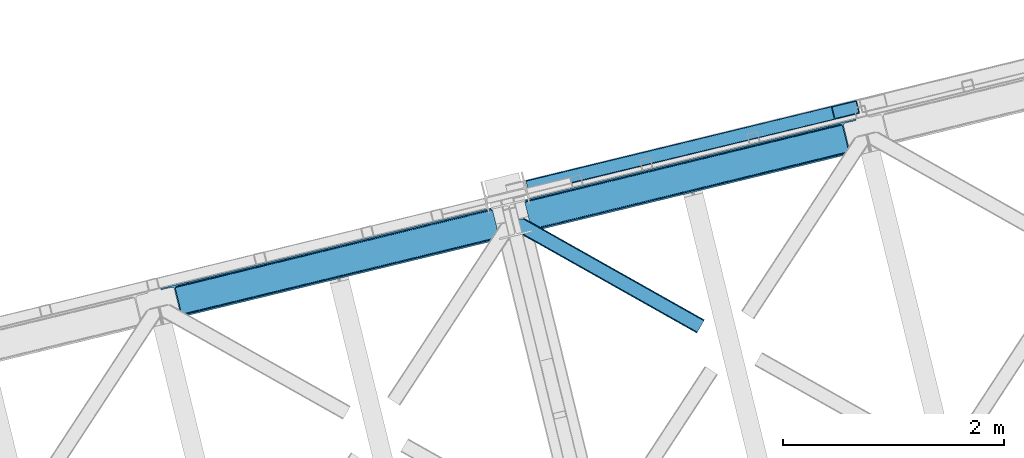
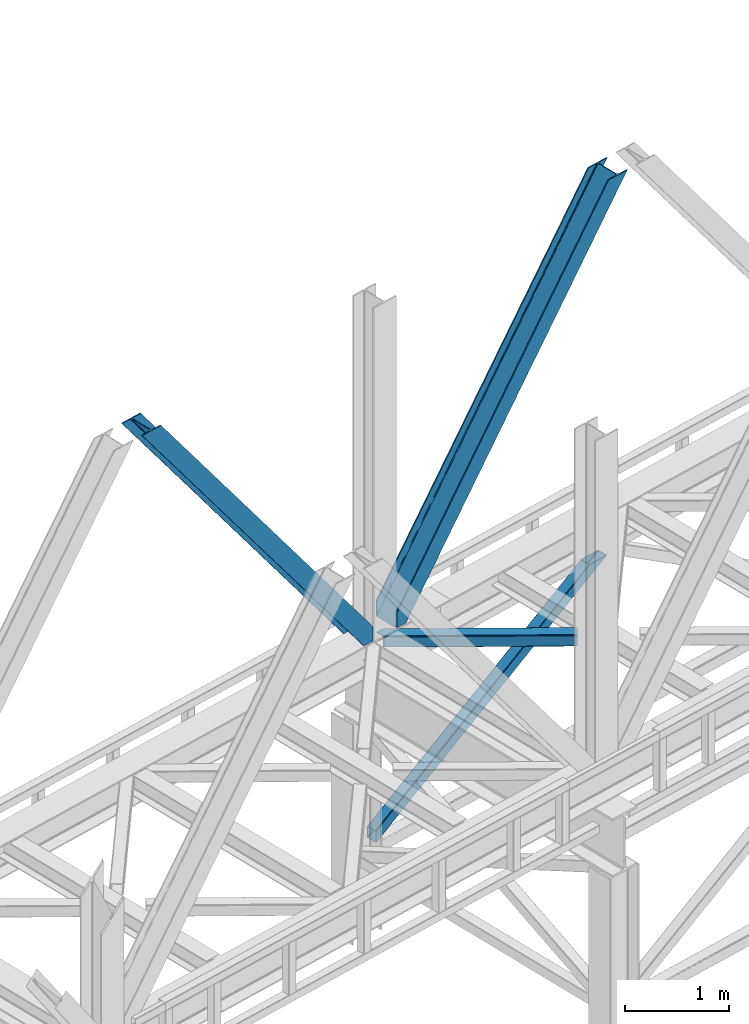
# One storey, part 46 of 92: 4 members.
"""IFC4 building model written with IfcOpenShell, lengths in millimetres."""

from ifc_helpers import new_model, entity, si_unit, converted_unit, derived_unit, direction, frame, origin, place, context, subcontext, project, spatial, triangles, type_object, element, save


model = new_model("IFC4")

# Units and contexts
model_context = context("Model", 3, precision=0.01, world=origin(), true_north=direction((6.12303176911189e-17, 1.0)))
plan_context = context("Plan", 3, precision=0.01, world=origin(), true_north=direction((6.12303176911189e-17, 1.0)))
body_context = subcontext(model_context, "Body", "Model", "MODEL_VIEW")
ifc_project = project(units=[si_unit("LENGTHUNIT", "METRE", prefix="MILLI"), si_unit("AREAUNIT", "SQUARE_METRE"), si_unit("VOLUMEUNIT", "CUBIC_METRE"), converted_unit("PLANEANGLEUNIT", "DEGREE", entity("IfcRatioMeasure", 0.0174532925199433), si_unit("PLANEANGLEUNIT", "RADIAN"), dimensions=[0, 0, 0, 0, 0, 0, 0]), si_unit("MASSUNIT", "GRAM", prefix="KILO"), derived_unit("MASSDENSITYUNIT", [(si_unit("MASSUNIT", "GRAM", prefix="KILO"), 1), (si_unit("LENGTHUNIT", "METRE"), -3)]), derived_unit("MOMENTOFINERTIAUNIT", [(si_unit("LENGTHUNIT", "METRE"), 4)]), si_unit("TIMEUNIT", "SECOND"), si_unit("FREQUENCYUNIT", "HERTZ"), si_unit("THERMODYNAMICTEMPERATUREUNIT", "DEGREE_CELSIUS"), derived_unit("THERMALTRANSMITTANCEUNIT", [(si_unit("MASSUNIT", "GRAM", prefix="KILO"), 1), (si_unit("THERMODYNAMICTEMPERATUREUNIT", "KELVIN"), -1), (si_unit("TIMEUNIT", "SECOND"), -3)]), derived_unit("VOLUMETRICFLOWRATEUNIT", [(si_unit("LENGTHUNIT", "METRE"), 3), (si_unit("TIMEUNIT", "SECOND"), -1)]), derived_unit("MASSFLOWRATEUNIT", [(si_unit("MASSUNIT", "GRAM", prefix="KILO"), 1), (si_unit("TIMEUNIT", "SECOND"), -1)]), derived_unit("ROTATIONALFREQUENCYUNIT", [(si_unit("TIMEUNIT", "SECOND"), -1)]), si_unit("ELECTRICCURRENTUNIT", "AMPERE"), si_unit("ELECTRICVOLTAGEUNIT", "VOLT"), si_unit("POWERUNIT", "WATT"), si_unit("FORCEUNIT", "NEWTON", prefix="KILO"), si_unit("ILLUMINANCEUNIT", "LUX"), si_unit("LUMINOUSFLUXUNIT", "LUMEN"), si_unit("LUMINOUSINTENSITYUNIT", "CANDELA"), derived_unit("USERDEFINED", [(si_unit("MASSUNIT", "GRAM", prefix="KILO"), -1), (si_unit("LENGTHUNIT", "METRE"), -2), (si_unit("TIMEUNIT", "SECOND"), 3), (si_unit("LUMINOUSFLUXUNIT", "LUMEN"), 1)]), derived_unit("LINEARVELOCITYUNIT", [(si_unit("LENGTHUNIT", "METRE"), 1), (si_unit("TIMEUNIT", "SECOND"), -1)]), si_unit("PRESSUREUNIT", "PASCAL"), derived_unit("USERDEFINED", [(si_unit("LENGTHUNIT", "METRE"), -2), (si_unit("MASSUNIT", "GRAM", prefix="KILO"), 1), (si_unit("TIMEUNIT", "SECOND"), -2)]), derived_unit("LINEARFORCEUNIT", [(si_unit("MASSUNIT", "GRAM", prefix="KILO"), 1), (si_unit("LENGTHUNIT", "METRE"), 1), (si_unit("TIMEUNIT", "SECOND"), -2), (si_unit("LENGTHUNIT", "METRE"), -1)]), derived_unit("PLANARFORCEUNIT", [(si_unit("MASSUNIT", "GRAM", prefix="KILO"), 1), (si_unit("LENGTHUNIT", "METRE"), 1), (si_unit("TIMEUNIT", "SECOND"), -2), (si_unit("LENGTHUNIT", "METRE"), -2)])], contexts=[model_context, plan_context])

# Site, building, storey
site_placement = place(None, origin())
site = spatial("IfcSite", under=ifc_project, at=site_placement, CompositionType="ELEMENT")
building_placement = place(site_placement, origin())
building = spatial("IfcBuilding", under=site, at=building_placement, CompositionType="ELEMENT")
storey_placement = place(building_placement, frame((0.0, 0.0, 15900.0)))
storey = spatial("IfcBuildingStorey", under=building, at=storey_placement, Name="05", CompositionType="ELEMENT", Elevation=15900.0)

# Members
member_type_1 = type_object("IfcMemberType", PredefinedType="BRACE")
member_1_placement = place(storey_placement, frame((-46122.29, 9414.76, 3695.0)))
element("IfcMember", 1, at=member_1_placement, inside=storey, type_object=member_type_1, ObjectType="Steel Vertical Brace", PredefinedType="BRACE", context=body_context, shape_type="Tessellation", body=[
    triangles([(3067.37091064453, 755.49225769043, 0.827856445310317), (3068.02668457031, 754.50743408203, 1.13248901367115), (3066.59886474609, 754.045834350585, 0.0), (3064.67805175781, 761.925585937499, 0.0), (3064.21761474609, 752.73196105957, 7.29955444335792), (3064.21761474609, 752.73196105957, 0.0), (3059.99926757813, 741.228012084961, 0.0), (3059.6876586914, 743.591821289063, 30.563250732419), (3059.80393066406, 742.210510253906, 42.2602111816377), (3059.81788330078, 745.527749633789, 0.0), (3059.81788330078, 745.527749633789, 24.1799194335908), (3059.80393066406, 742.210510253906, 171.115136718749), (3059.99926757813, 741.228012084961, 171.175598144531), (3061.29686279297, 749.56936340332, 14.6921264648408), (3061.29686279297, 749.56936340332, 0.0), (3060.72015380859, 747.995040893555, 18.3872497558586), (215.726367187497, 48.9359664916992, 3911.00081176758), (310.450817871089, 72.0264175415032, 3911.00081176758), (192.834741210936, 54.7931671142578, 3911.00081176758), (198.969250488277, 50.2783264160153, 3911.00081176758), (207.010620117188, 48.2214752197269, 3911.00081176758), (189.532617187499, 61.0782485961918, 3911.00081176758), (3062.84095458984, 729.569421386719, 171.175598144531), (313.529699707025, 59.396374511718, 3911.00081176758), (3062.84095458984, 729.569421386719, 0.0), (2945.0109375, 700.846755981445, 0.0), (69.865502929686, 0.0, 3911.00081176758), (2941.93205566406, 713.477380371094, 0.0), (66.78662109375, 12.6300430297852, 3911.00081176758), (161.511071777342, 35.7204940795891, 3911.00081176758), (3036.65650634765, 736.567831420898, 0.0), (3054.3251953125, 759.401321411133, 0.0), (3054.28333740234, 752.301754760741, 0.0), (179.179760742183, 58.5539840698239, 3911.00081176758), (179.13790283203, 51.4544174194325, 3911.00081176758), (3050.91610107422, 745.469613647461, 0.0), (175.7706665039, 44.622857666016, 3911.00081176758), (3044.72578125, 739.944369506835, 0.0), (169.580346679686, 39.0970321655277, 3911.00081176758), (2999.14251708984, 985.772387695311, 0.0), (123.997082519527, 284.925631713866, 3911.00081176758), (2972.94876708984, 997.914669799804, 0.0), (2981.66916503906, 998.62974243164, 0.0), (106.523730468747, 297.782405090331, 3911.00081176758), (97.8033325195283, 297.067913818359, 3911.00081176758), (2989.70588378906, 996.572891235352, 0.0), (114.560449218749, 295.725553894043, 3911.00081176758), (2995.84039306641, 992.058050537109, 0.0), (120.694958496089, 291.211294555664, 3911.00081176758), (3.07888183593604, 273.977462768555, 3911.00081176758), (2878.22431640625, 974.82421875, 0.0), (2875.14543457031, 987.454843139649, 0.0), (0.0, 286.60750579834, 3911.00081176758), (3009.50002441406, 988.296652221679, 0.0), (134.354589843744, 287.449896240234, 3911.00081176758), (143.954003906249, 306.906266784668, 3911.00081176758), (243.668847656249, 346.004461669922, 3911.00081176758), (152.018627929683, 310.283386230469, 3911.00081176758), (137.763684082027, 301.381604003906, 3911.00081176758), (134.391796874996, 294.549462890625, 3911.00081176758), (246.747729492185, 333.373837280273, 3911.00081176758), (2992.97545166015, 1016.17750854492, 171.175598144531), (2992.97545166015, 1016.17750854492, 0.0), (2995.81713867188, 1004.51891784668, 171.175598144531), (2996.10084228515, 1003.55734863281, 171.115136718749), (2996.10084228515, 1003.55734863281, 42.2602111816377), (2995.81713867188, 1004.51891784668, 0.0), (3004.85844726562, 996.247329711914, 0.0), (2997.63563232421, 1000.61683044434, 0.0), (3000.81218261718, 997.712356567383, 0.0), (3007.57921142578, 996.176403808593, 0.0), (2996.63104248047, 1002.27719421387, 30.563250732419), (2997.79841308593, 1000.74124145508, 25.1542785644524), (2999.21228027344, 998.890191650391, 18.6337463378877), (3000.81218261718, 997.712356567383, 14.6921264648408), (3004.85844726562, 996.247329711914, 7.29955444335792), (3009.05819091797, 996.424063110351, 1.13248901367115), (3008.92796630859, 995.248553466796, 0.827856445310317)], [[1, 2, 3], [3, 4, 1], [5, 6, 3], [7, 8, 9], [7, 10, 11], [11, 8, 7], [9, 12, 13], [13, 7, 9], [14, 10, 15], [10, 14, 16], [11, 10, 16], [6, 5, 15], [14, 15, 5], [3, 2, 5], [17, 18, 12], [12, 9, 17], [1, 19, 5], [19, 20, 16], [16, 14, 19], [14, 5, 19], [20, 21, 8], [8, 11, 20], [9, 8, 21], [21, 17, 9], [11, 16, 20], [5, 2, 1], [1, 4, 19], [22, 19, 4], [13, 12, 18], [23, 13, 24], [18, 24, 13], [23, 25, 7], [7, 13, 23], [24, 26, 23], [24, 27, 26], [26, 25, 23], [28, 26, 29], [27, 29, 26], [29, 30, 28], [31, 28, 30], [32, 33, 34], [35, 34, 33], [33, 36, 35], [37, 35, 36], [36, 38, 37], [39, 37, 38], [38, 31, 39], [30, 39, 31], [40, 32, 41], [34, 41, 32], [42, 43, 44], [44, 45, 42], [43, 46, 47], [47, 44, 43], [46, 48, 49], [49, 47, 46], [48, 40, 41], [41, 49, 48], [45, 50, 51], [51, 42, 45], [52, 51, 50], [50, 53, 52], [4, 54, 55], [55, 22, 4], [41, 34, 55], [37, 39, 21], [30, 27, 24], [29, 27, 30], [39, 30, 17], [34, 35, 19], [35, 37, 20], [47, 56, 44], [53, 45, 57], [45, 44, 58], [53, 50, 45], [47, 49, 59], [49, 41, 60], [55, 34, 22], [17, 21, 39], [19, 35, 20], [21, 20, 37], [19, 22, 34], [24, 17, 30], [24, 18, 17], [58, 44, 56], [59, 49, 60], [55, 60, 41], [59, 56, 47], [58, 57, 45], [57, 58, 61], [57, 52, 53], [52, 57, 62], [63, 52, 62], [64, 62, 57], [65, 64, 61], [57, 61, 64], [61, 58, 65], [66, 65, 58], [64, 67, 62], [63, 62, 67], [32, 40, 54], [46, 43, 67], [42, 52, 63], [51, 52, 42], [43, 42, 63], [40, 48, 68], [48, 46, 69], [36, 7, 38], [26, 31, 25], [31, 38, 25], [26, 28, 31], [36, 33, 10], [33, 32, 6], [10, 7, 36], [54, 40, 68], [67, 69, 46], [63, 67, 43], [48, 69, 70], [70, 68, 48], [71, 54, 68], [32, 54, 4], [10, 33, 15], [33, 6, 15], [7, 25, 38], [32, 4, 6], [3, 6, 4], [67, 72, 73], [65, 66, 64], [67, 64, 66], [66, 72, 67], [69, 74, 75], [69, 73, 74], [76, 77, 71], [71, 68, 76], [76, 68, 70], [70, 75, 76], [75, 70, 69], [73, 69, 67], [60, 78, 76], [76, 59, 60], [76, 75, 59], [75, 74, 59], [78, 77, 76], [54, 78, 60], [60, 55, 54], [73, 59, 74], [59, 73, 72], [56, 59, 72], [72, 66, 56], [58, 56, 66], [77, 78, 71], [54, 71, 78]]),
])
member_type_2 = type_object("IfcMemberType", PredefinedType="BRACE")
member_2_placement = place(storey_placement, frame((-42823.61, 10220.12, 3695.0)))
element("IfcMember", 2, at=member_2_placement, inside=storey, type_object=member_type_2, ObjectType="Steel Vertical Brace", PredefinedType="BRACE", context=body_context, shape_type="Tessellation", body=[
    triangles([(58.5313110351563, 27.8808563232415, 0.0), (60.452124023439, 20.0011047363278, 0.0), (59.0987182617173, 20.928955078125, 0.827856445310317), (58.97314453125, 19.7534454345696, 1.13248901367115), (72.2095458984404, 11.6585906982418, 0.0), (71.4002929687485, 13.9003143310547, 30.563250732419), (70.228271484375, 15.4362670898427, 25.1542785644524), (72.2095458984404, 11.6585906982418, 171.175598144531), (71.9304931640654, 12.6201599121086, 42.2602111816377), (71.9304931640654, 12.6201599121086, 171.115136718749), (70.3957031250029, 15.5606781005863, 0.0), (68.8190551757798, 17.2873168945316, 18.6337463378877), (67.2191528320327, 18.4663146972653, 14.6921264648408), (63.168237304686, 19.9301788330067, 7.29955444335792), (63.168237304686, 19.9301788330067, 0.0), (67.2191528320327, 18.4663146972653, 0.0), (2821.28360595703, 682.803671264648, 3911.00081176758), (2916.00805664063, 705.894122314452, 3911.00081176758), (2933.63488769531, 721.628045654297, 3911.00081176758), (2930.26765136719, 714.795904541015, 3911.00081176758), (2933.67674560547, 728.727612304687, 3911.00081176758), (2924.07733154297, 709.270660400391, 3911.00081176758), (2824.36248779297, 670.173046874999, 3911.00081176758), (75.0512329101548, 0.0, 171.175598144531), (75.0512329101548, 0.0, 0.0), (192.881249999999, 28.7226654052738, 0.0), (3068.03133544922, 729.570584106445, 3911.00081176758), (3064.95245361328, 742.200045776366, 3911.00081176758), (189.802368164063, 41.3532897949208, 0.0), (2970.22335205078, 719.109594726562, 3911.00081176758), (95.0779174804702, 18.2628387451168, 0.0), (2961.50760498047, 718.395684814453, 3911.00081176758), (86.3621704101533, 17.5477661132809, 0.0), (2953.47088623047, 720.451373291015, 3911.00081176758), (78.32080078125, 19.6046173095692, 0.0), (2947.33172607422, 724.966213989257, 3911.00081176758), (72.1862915039092, 24.1194580078118, 0.0), (2944.02960205078, 731.251876831055, 3911.00081176758), (68.8841674804717, 30.4039581298821, 0.0), (2888.85157470703, 957.624105834961, 3911.00081176758), (13.7061401367173, 256.776187133788, 0.0), (2888.88878173828, 964.722509765625, 3911.00081176758), (13.7433471679688, 263.875753784179, 0.0), (2892.26066894531, 971.554650878907, 3911.00081176758), (17.115234375, 270.707894897461, 0.0), (2898.45098876953, 977.079895019531, 3911.00081176758), (23.3055541992217, 276.233139038086, 0.0), (2906.52026367188, 980.457595825195, 3911.00081176758), (31.3748291015654, 279.609677124023, 0.0), (3001.24471435547, 1003.548046875, 3911.00081176758), (126.099279785158, 302.700128173828, 0.0), (2998.16583251953, 1016.17750854492, 3911.00081176758), (123.020397949222, 315.330752563475, 0.0), (2878.49406738281, 955.098678588867, 3911.00081176758), (3.3486328125, 254.251922607422, 0.0), (2869.05743408203, 965.899182128906, 3911.00081176758), (2861.02071533203, 967.956033325196, 3911.00081176758), (2754.49698486328, 956.781134033203, 3911.00081176758), (2852.30496826172, 967.242123413085, 3911.00081176758), (2757.57586669922, 944.150509643554, 3911.00081176758), (2875.19194335937, 961.384341430663, 3911.00081176758), (5.19038085937791, 286.608087158203, 171.175598144531), (5.19038085937791, 286.608087158203, 0.0), (8.03206787109229, 274.94949645996, 171.175598144531), (8.22275390625146, 273.966998291015, 171.115136718749), (8.22275390625146, 273.966998291015, 42.2602111816377), (8.03206787109229, 274.94949645996, 0.0), (3.80906982421584, 263.445547485351, 0.0), (6.72982177734229, 266.608145141601, 0.0), (8.21345214844041, 270.649758911133, 0.0), (1.42781982421729, 262.130511474608, 0.0), (3.80906982421584, 263.445547485351, 7.29955444335792), (8.34367675780959, 272.58568725586, 30.563250732419), (8.21345214844041, 270.649758911133, 24.1799194335908), (7.30653076172166, 268.182467651366, 18.3872497558586), (6.72982177734229, 266.608145141601, 14.6921264648408), (0.0, 261.670074462891, 1.13248901367115), (0.65577392578416, 260.685250854493, 0.827856445310317)], [[1, 2, 3], [4, 3, 2], [5, 6, 7], [5, 8, 9], [10, 9, 8], [9, 6, 5], [11, 12, 13], [11, 7, 12], [14, 4, 2], [2, 15, 14], [16, 13, 14], [14, 15, 16], [13, 16, 11], [7, 11, 5], [17, 18, 10], [9, 10, 18], [19, 3, 14], [14, 20, 19], [14, 13, 20], [13, 12, 20], [3, 4, 14], [19, 21, 1], [1, 3, 19], [6, 20, 7], [6, 22, 20], [12, 7, 20], [18, 22, 9], [6, 9, 22], [8, 17, 10], [23, 8, 24], [8, 23, 17], [25, 24, 5], [8, 5, 24], [23, 26, 27], [26, 23, 24], [25, 26, 24], [28, 27, 26], [26, 29, 28], [30, 28, 29], [29, 31, 30], [32, 30, 31], [31, 33, 32], [34, 32, 33], [33, 35, 34], [36, 34, 35], [35, 37, 36], [38, 36, 37], [37, 39, 38], [40, 38, 39], [39, 41, 40], [42, 40, 43], [41, 43, 40], [44, 42, 45], [43, 45, 42], [46, 44, 47], [45, 47, 44], [48, 46, 49], [47, 49, 46], [50, 48, 51], [49, 51, 48], [52, 50, 53], [51, 53, 50], [21, 54, 55], [55, 1, 21], [54, 21, 40], [20, 22, 32], [18, 23, 27], [17, 23, 18], [22, 18, 30], [21, 19, 36], [19, 20, 34], [56, 46, 57], [58, 59, 52], [59, 57, 48], [58, 60, 59], [56, 61, 44], [61, 54, 42], [40, 21, 38], [30, 32, 22], [36, 19, 34], [32, 34, 20], [36, 38, 21], [27, 30, 18], [27, 28, 30], [48, 57, 46], [44, 61, 42], [40, 42, 54], [44, 46, 56], [48, 52, 59], [52, 48, 50], [58, 53, 62], [58, 52, 53], [53, 63, 62], [64, 58, 62], [60, 64, 65], [64, 60, 58], [59, 60, 65], [65, 66, 59], [67, 64, 62], [62, 63, 67], [11, 35, 5], [68, 41, 55], [69, 70, 43], [69, 43, 68], [55, 71, 68], [67, 63, 47], [67, 45, 70], [55, 39, 1], [37, 16, 15], [2, 1, 15], [15, 1, 39], [11, 16, 37], [25, 5, 33], [39, 55, 41], [49, 47, 63], [43, 70, 45], [47, 45, 67], [43, 41, 68], [53, 49, 63], [53, 51, 49], [31, 25, 33], [35, 11, 37], [39, 37, 15], [35, 33, 5], [31, 26, 25], [26, 31, 29], [72, 68, 71], [67, 73, 66], [67, 70, 74], [74, 73, 67], [64, 67, 66], [66, 65, 64], [75, 70, 76], [75, 74, 70], [69, 76, 70], [76, 69, 72], [68, 72, 69], [71, 77, 72], [78, 61, 72], [61, 56, 75], [75, 76, 61], [76, 72, 61], [56, 57, 73], [73, 74, 56], [57, 59, 66], [66, 73, 57], [74, 75, 56], [72, 77, 78], [54, 61, 55], [78, 55, 61], [71, 55, 78], [78, 77, 71]]),
])
member_type_3 = type_object("IfcMemberType", PredefinedType="BRACE")
member_3_placement = place(storey_placement, frame((-42813.64, 10559.94, 965.74)))
element("IfcMember", 3, at=member_3_placement, inside=storey, type_object=member_type_3, ObjectType="Steel Vertical Brace", PredefinedType="BRACE", context=body_context, shape_type="Tessellation", body=[
    triangles([(2998.54720458984, 840.489395141602, 1902.27225952148), (3024.23865966796, 734.56097717285, 1902.27225952148), (42.5415893554673, 11.3690734863267, 4.45903015136719), (16.6268920898438, 117.244006347655, 4.31717834472511), (0.176733398438955, 120.724026489257, 0.782510375975107), (0.0, 121.443749999999, 4.34159545898365), (2981.88310546875, 844.679837036132, 1902.27225952148), (2987.68275146484, 845.460021972656, 1902.27225952148), (2992.88243408203, 844.937960815429, 1902.27225952148), (7.26932373047021, 120.796115112304, 1.96615905761428), (2996.70080566406, 843.192718505859, 1902.27225952148), (13.8177612304644, 119.712460327148, 3.70442504882521), (0.213940429683134, 120.565896606444, 0.0), (3016.85771484375, 725.1650390625, 1902.27225952148), (29.4307617187515, 0.711584472655886, 0.868551635740005), (35.8768798828096, 3.93231811523401, 2.12312622070021), (29.3935546875, 0.86041259765625, 0.127899169921875), (3011.34642333984, 723.202368164062, 1902.27225952148), (29.6028442382813, 0.0, 4.43112487792678), (3021.24349365234, 728.013702392578, 1902.27225952148), (3023.83868408203, 731.313500976561, 1902.27225952148), (41.1881835937456, 7.89021606445203, 3.8532531738274), (0.0, 121.443749999999, 132.509353637695), (2780.51865234375, 795.839794921874, 1902.27225952148), (0.279052734375, 120.305447387695, 135.835894775388), (2775.00270996094, 793.875961303711, 1902.27225952148), (0.55810546875, 119.167144775391, 139.162435913084), (2770.61693115234, 791.028460693358, 1902.27225952148), (1.22783203124709, 116.419638061523, 140.541421508788), (2768.02639160156, 787.728662109374, 1902.27225952148), (1.89755859375146, 113.670968627928, 141.921569824219), (2767.62176513672, 784.481185913086, 1902.27225952148), (2793.31787109375, 678.552767944335, 1902.27225952148), (27.709936523439, 7.77161865234302, 141.999472045896), (28.379663085936, 5.02411193847547, 140.622811889647), (2795.16427001953, 675.849444580077, 1902.27225952148), (29.0493896484331, 2.27544250488245, 139.247314453125), (2798.97799072265, 674.104202270508, 1902.27225952148), (29.3284423828081, 1.13713989257667, 135.92309875488), (2804.18232421875, 673.58214111328, 1902.27225952148), (29.6028442382813, 0.0, 132.597720336911), (2809.98197021485, 674.362326049804, 1902.27225952148), (3.90208740234084, 110.042120361328, 0.32207336425563), (27.914575195311, 11.9376434326168, 0.453460693359375), (27.3099609374985, 9.42151794433448, 0.118597412107192), (2.32078857421584, 111.925726318359, 0.00930175781104481), (3015.90893554688, 736.656198120116, 1902.27225952148), (2992.10108642578, 834.810671997069, 1902.27225952148), (1.6278076171875, 114.77322692871, 3.08236999511428), (2986.44096679687, 839.258074951171, 1902.27225952148), (2981.23663330078, 839.780136108398, 1902.27225952148), (2.17196044921729, 112.538479614257, 0.67088928222438), (2990.2546875, 837.512832641602, 1902.27225952148), (1.09295654296875, 116.966116333007, 5.44850463866896), (2975.43698730469, 839.001113891602, 1902.27225952148), (0.94877929687209, 117.557940673827, 9.04828491210719), (28.379663085936, 5.02411193847547, 5.80429687499782), (28.658715820311, 3.88580932617151, 9.13083801269386), (3003.01669921875, 725.297589111327, 1902.27225952148), (28.100610351561, 6.16241455078125, 2.47775573730178), (3008.52799072266, 727.261422729491, 1902.27225952148), (27.4680908203081, 8.76109313964844, 0.596475219725107), (3012.91376953125, 730.108923339843, 1902.27225952148), (3015.50430908203, 733.408721923828, 1902.27225952148), (0.94877929687209, 117.557940673827, 127.808477783201), (2788.84837646484, 793.744573974609, 1902.27225952148), (2.17196044921729, 112.532666015624, 135.841708374021), (2776.36076660156, 785.633441162108, 1902.27225952148), (2775.95614013672, 782.385964965819, 1902.27225952148), (1.50223388672021, 115.281335449217, 134.461560058593), (2778.95130615234, 788.933239746093, 1902.27225952148), (1.22783203124709, 116.419638061523, 131.135018920897), (2783.33708496093, 791.780740356444, 1902.27225952148), (2.84168701171438, 109.785159301757, 137.220693969724), (2805.42410888672, 679.784088134766, 1902.27225952148), (2801.6103881836, 681.529330444335, 1902.27225952148), (2816.4280883789, 680.041049194335, 1902.27225952148), (2810.62844238281, 679.262026977538, 1902.27225952148), (2799.75933837891, 684.231491088867, 1902.27225952148), (28.379663085936, 5.02411193847547, 131.216409301756), (28.100610351561, 6.16241455078125, 134.541787719725), (27.430883789064, 8.90992126464698, 135.917285156247), (26.7611572265596, 11.6574279785145, 137.292782592773), (28.658715820311, 3.88580932617151, 127.891030883788)], [[1, 2, 3], [3, 4, 1], [5, 6, 7], [8, 9, 10], [10, 5, 8], [11, 1, 4], [4, 12, 11], [9, 11, 12], [12, 10, 9], [10, 13, 5], [7, 8, 5], [14, 15, 16], [15, 17, 16], [15, 14, 18], [18, 19, 15], [16, 20, 14], [21, 20, 22], [16, 22, 20], [2, 21, 3], [22, 3, 21], [6, 23, 24], [24, 7, 6], [23, 25, 26], [25, 27, 28], [27, 29, 30], [29, 31, 32], [32, 30, 29], [30, 28, 27], [28, 26, 25], [26, 24, 23], [33, 32, 34], [31, 34, 32], [35, 36, 33], [37, 38, 36], [39, 40, 38], [41, 42, 40], [40, 39, 41], [38, 37, 39], [36, 35, 37], [33, 34, 35], [41, 19, 42], [18, 42, 19], [43, 10, 12], [44, 3, 22], [44, 22, 16], [3, 44, 4], [12, 4, 43], [43, 4, 44], [16, 45, 44], [16, 17, 45], [10, 46, 13], [46, 10, 43], [47, 48, 44], [43, 44, 48], [49, 50, 51], [52, 53, 50], [53, 46, 43], [53, 52, 46], [43, 48, 53], [50, 49, 52], [51, 54, 49], [51, 55, 54], [56, 54, 55], [57, 58, 59], [60, 57, 61], [62, 60, 63], [64, 47, 44], [44, 45, 64], [45, 62, 64], [63, 64, 62], [61, 63, 60], [59, 61, 57], [65, 56, 66], [55, 66, 56], [67, 68, 69], [70, 71, 68], [72, 73, 71], [65, 66, 73], [73, 72, 65], [71, 70, 72], [68, 67, 70], [69, 74, 67], [53, 9, 8], [48, 47, 1], [11, 53, 1], [53, 11, 9], [53, 48, 1], [50, 53, 8], [55, 7, 24], [7, 50, 8], [51, 7, 55], [51, 50, 7], [20, 64, 14], [47, 2, 1], [2, 64, 21], [64, 2, 47], [20, 21, 64], [18, 59, 42], [14, 64, 63], [63, 61, 18], [61, 59, 18], [18, 14, 63], [71, 26, 68], [24, 66, 55], [24, 73, 66], [71, 24, 26], [71, 73, 24], [69, 32, 33], [68, 26, 28], [30, 68, 28], [68, 30, 32], [69, 68, 32], [40, 75, 76], [42, 59, 77], [77, 78, 42], [78, 75, 42], [40, 42, 75], [38, 40, 76], [33, 79, 69], [76, 33, 36], [33, 76, 79], [36, 38, 76], [41, 39, 80], [81, 35, 82], [37, 81, 39], [81, 37, 35], [80, 39, 81], [83, 31, 74], [82, 35, 34], [34, 83, 82], [34, 31, 83], [80, 84, 41], [19, 60, 17], [19, 41, 84], [84, 58, 19], [19, 58, 57], [60, 19, 57], [60, 62, 17], [23, 65, 72], [70, 25, 72], [31, 29, 67], [31, 67, 74], [67, 29, 70], [25, 23, 72], [70, 29, 27], [70, 27, 25], [23, 56, 65], [49, 13, 46], [49, 54, 5], [5, 13, 49], [54, 56, 6], [23, 6, 56], [54, 6, 5], [69, 79, 83], [83, 74, 69], [84, 80, 78], [80, 81, 75], [81, 82, 76], [82, 83, 79], [79, 76, 82], [76, 75, 81], [75, 78, 80], [78, 77, 84], [58, 84, 77], [77, 59, 58]]),
])
member_type_4 = type_object("IfcMemberType", PredefinedType="BRACE")
member_4_placement = place(storey_placement, frame((-42920.63, 9296.6, 3511.0)))
element("IfcMember", 4, at=member_4_placement, inside=storey, type_object=member_type_4, ObjectType="Steel Horizontal Brace", PredefinedType="BRACE", context=body_context, shape_type="Tessellation", body=[
    triangles([(1656.08961181641, 0.0, 122.500662231447), (1656.74073486328, 1.16039428710974, 129.197927856447), (23.8869140625029, 919.172383117675, 122.500662231447), (23.4543823242202, 920.945530700683, 129.197927856447), (1658.60573730469, 4.46600646972547, 134.874325561526), (22.2265502929731, 925.991734313964, 134.874325561526), (1661.38696289063, 9.41279754638708, 138.667117309571), (20.3848022460952, 933.543598937988, 138.667117309571), (1664.67513427735, 15.2484878540035, 139.999594116212), (18.2128417968779, 942.452357482909, 139.999594116212), (1656.08961181641, 0.0, 17.5000946044929), (23.8869140625029, 919.172383117675, 17.5000946044929), (1716.19757080078, 106.738252258301, 139.999594116212), (69.4422729492217, 1034.10722808838, 139.999594116212), (0.0, 1017.17919158936, 139.999594116212), (1719.48574218751, 112.573361206054, 138.667117309571), (78.9672729492231, 1036.42917938232, 138.667117309571), (1722.27161865235, 117.520733642577, 134.874325561526), (87.0458496093779, 1038.39766387939, 134.874325561526), (1724.13197021485, 120.825764465331, 129.197927856447), (92.4408691406279, 1039.71269989014, 129.197927856447), (1724.78309326172, 121.986158752441, 122.500662231447), (94.3337768554702, 1040.17429962158, 122.500662231447), (1724.78309326172, 121.986158752441, 17.5000946044929), (94.3337768554702, 1040.17429962158, 17.5000946044929), (1656.74073486328, 1.16039428710974, 10.8028289794929), (1658.60573730469, 4.46600646972547, 5.12526855468968), (196.053149414067, 824.821165466308, 8.8831787109375), (196.071752929689, 825.066499328614, 8.50064392089917), (23.3660156250044, 921.307136535645, 10.8691040039084), (195.062512207034, 824.999061584473, 9.50058288574292), (195.732238769531, 824.879301452636, 9.08316650390771), (23.2590454101592, 921.747807312011, 9.50058288574292), (195.220642089844, 828.569773864745, 5.12526855468968), (1664.67513427735, 15.2484878540035, 0.0), (1661.38696289063, 9.41279754638708, 1.33247680664135), (193.378894042973, 836.122801208496, 1.33247680664135), (191.206933593756, 845.031559753417, 0.0), (1716.19757080078, 106.738252258301, 0.0), (157.157849121097, 984.711405944823, 0.0), (191.346459960943, 843.223530578613, 9.20757751465135), (191.290649414063, 844.068827819823, 8.85411071777344), (191.104614257813, 845.46060333252, 8.41343994140698), (18.8686157226621, 939.77345123291, 9.50058288574292), (1724.13197021485, 120.825764465331, 10.8028289794929), (92.0548461914077, 1039.61851959228, 10.8702667236357), (150.916369628911, 1006.08800811767, 9.50058288574292), (1722.27161865235, 117.520733642577, 5.12526855468968), (153.144140625001, 1001.17202911377, 5.12526855468968), (152.293029785156, 1004.67646636963, 8.50064392089917), (151.604699707037, 1005.38223724365, 9.00061340332104), (91.5804565429717, 1039.50341033936, 9.50058288574292), (1719.48574218751, 112.573361206054, 1.33247680664135), (154.985888671879, 993.620164489746, 1.33247680664135), (156.246276855469, 986.7019821167, 9.11688537597729), (155.809094238284, 987.634483337402, 9.42384338378906), (156.692761230472, 985.761341857909, 8.80760192871094), (157.129943847656, 984.828840637207, 8.50064392089917), (155.311450195317, 988.062364196778, 9.50058288574292), (72.3072143554746, 1034.80602264404, 9.50058288574292), (159.427478027348, 975.399183654785, 6.99957275390625), (188.937304687504, 854.343782043457, 6.99957275390625), (1668.11213378907, 21.3475341796875, 6.99957275390625), (1712.76522216797, 100.639205932617, 6.99957275390625), (19.9569213867217, 935.302793884277, 12.1260040283232), (1662.0380859375, 10.5656341552731, 12.1260040283232), (1664.82396240235, 15.5124252319329, 8.3320495605476), (1659.52196044922, 6.09904632568396, 24.4996673583992), (1660.177734375, 7.26002197265552, 17.8035644531265), (21.6172851562515, 928.484605407715, 24.4996673583992), (21.1847534179688, 930.256590270996, 17.8035644531265), (1716.04874267578, 106.47431488037, 8.3320495605476), (1718.83461914063, 111.421105957032, 12.1260040283232), (77.0883178710938, 1035.97106781006, 12.1260040283232), (1720.69497070313, 114.726718139647, 17.8035644531265), (82.4833374023438, 1037.2861038208, 17.8035644531265), (1721.35074462891, 115.887112426757, 24.4996673583992), (84.3808959960952, 1037.74770355225, 24.4996673583992), (1659.52196044922, 6.09904632568396, 115.501089477541), (21.6172851562515, 928.484605407715, 115.501089477541), (21.1847534179688, 930.256590270996, 122.196029663086), (19.9569213867217, 935.302793884277, 127.87475280762), (15.9432128906265, 951.764579772949, 133.000021362306), (18.1151733398438, 942.855821228028, 131.667544555665), (0.0, 1017.17919158936, 133.000021362306), (1668.11213378907, 21.3475341796875, 133.000021362306), (1664.82396240235, 15.5124252319329, 131.667544555665), (1662.0380859375, 10.5656341552731, 127.87475280762), (1660.177734375, 7.26002197265552, 122.196029663086), (1718.83461914063, 111.421105957032, 127.87475280762), (1720.69497070313, 114.726718139647, 122.196029663086), (1721.35074462891, 115.887112426757, 115.501089477541), (1712.76522216797, 100.639205932617, 133.000021362306), (1716.04874267578, 106.47431488037, 131.667544555665), (77.0883178710938, 1035.97106781006, 127.87475280762), (69.0143920898481, 1034.00258331299, 131.667544555665), (82.4833374023438, 1037.2861038208, 122.196029663086), (59.4893920898467, 1031.68063201904, 133.000021362306), (84.3808959960952, 1037.74770355225, 115.501089477541)], [[1, 2, 3], [4, 3, 2], [2, 5, 4], [6, 4, 5], [5, 7, 6], [8, 6, 7], [7, 9, 8], [10, 8, 9], [11, 1, 12], [3, 12, 1], [13, 10, 9], [10, 13, 14], [15, 10, 14], [13, 16, 17], [17, 14, 13], [16, 18, 19], [19, 17, 16], [18, 20, 21], [21, 19, 18], [20, 22, 23], [23, 21, 20], [22, 24, 23], [25, 23, 24], [26, 11, 12], [27, 28, 29], [26, 30, 31], [31, 27, 26], [31, 32, 27], [30, 33, 31], [29, 34, 27], [35, 36, 37], [37, 38, 35], [36, 27, 34], [34, 37, 36], [12, 30, 26], [39, 35, 38], [38, 40, 39], [41, 42, 29], [42, 43, 29], [41, 31, 33], [33, 44, 41], [45, 46, 25], [46, 45, 47], [45, 48, 49], [49, 50, 45], [45, 50, 51], [51, 47, 45], [47, 52, 46], [48, 53, 54], [54, 49, 48], [53, 39, 40], [40, 54, 53], [25, 24, 45], [51, 55, 56], [50, 57, 55], [50, 58, 57], [47, 59, 52], [60, 52, 59], [61, 40, 62], [54, 58, 49], [58, 54, 40], [49, 58, 50], [40, 61, 58], [62, 40, 38], [37, 43, 38], [43, 37, 34], [38, 43, 62], [34, 29, 43], [63, 64, 62], [61, 62, 64], [63, 62, 43], [41, 65, 66], [41, 44, 65], [43, 66, 67], [66, 43, 42], [42, 41, 66], [43, 67, 63], [68, 69, 70], [71, 70, 69], [69, 66, 71], [65, 71, 66], [72, 58, 61], [57, 72, 55], [57, 58, 72], [56, 55, 72], [73, 74, 59], [59, 72, 73], [74, 60, 59], [73, 75, 76], [76, 74, 73], [75, 77, 78], [78, 76, 75], [61, 64, 72], [79, 68, 80], [70, 80, 68], [81, 6, 82], [80, 70, 3], [4, 81, 3], [81, 4, 6], [81, 80, 3], [70, 12, 3], [71, 65, 33], [33, 30, 71], [30, 12, 71], [70, 71, 12], [83, 10, 15], [10, 84, 8], [84, 10, 83], [15, 85, 83], [84, 82, 8], [44, 33, 65], [8, 82, 6], [86, 87, 84], [84, 83, 86], [87, 88, 82], [82, 84, 87], [88, 89, 81], [81, 82, 88], [89, 79, 80], [80, 81, 89], [20, 90, 91], [92, 24, 22], [20, 91, 22], [20, 18, 90], [91, 92, 22], [90, 18, 16], [93, 13, 9], [13, 94, 16], [94, 13, 93], [94, 90, 16], [45, 73, 48], [77, 24, 92], [24, 75, 45], [75, 24, 77], [45, 75, 73], [39, 64, 35], [53, 48, 73], [73, 72, 53], [72, 64, 39], [39, 53, 72], [88, 7, 5], [9, 86, 93], [9, 87, 86], [87, 9, 7], [88, 87, 7], [79, 1, 11], [2, 89, 88], [5, 2, 88], [89, 2, 1], [79, 89, 1], [36, 66, 27], [35, 64, 63], [63, 67, 35], [67, 66, 36], [36, 35, 67], [26, 27, 66], [11, 68, 79], [69, 11, 26], [11, 69, 68], [69, 26, 66], [95, 96, 17], [19, 95, 17], [19, 21, 97], [95, 19, 97], [97, 21, 23], [96, 14, 17], [15, 98, 85], [15, 14, 98], [96, 98, 14], [97, 23, 99], [78, 25, 76], [23, 78, 99], [25, 46, 76], [23, 25, 78], [52, 76, 46], [74, 76, 52], [60, 74, 52], [93, 83, 98], [93, 86, 83], [83, 85, 98], [77, 92, 99], [99, 78, 77], [92, 91, 99], [97, 99, 91], [91, 90, 97], [95, 97, 90], [90, 94, 95], [96, 95, 94], [94, 93, 96], [98, 96, 93]]),
])

save(model, "model.ifc")
